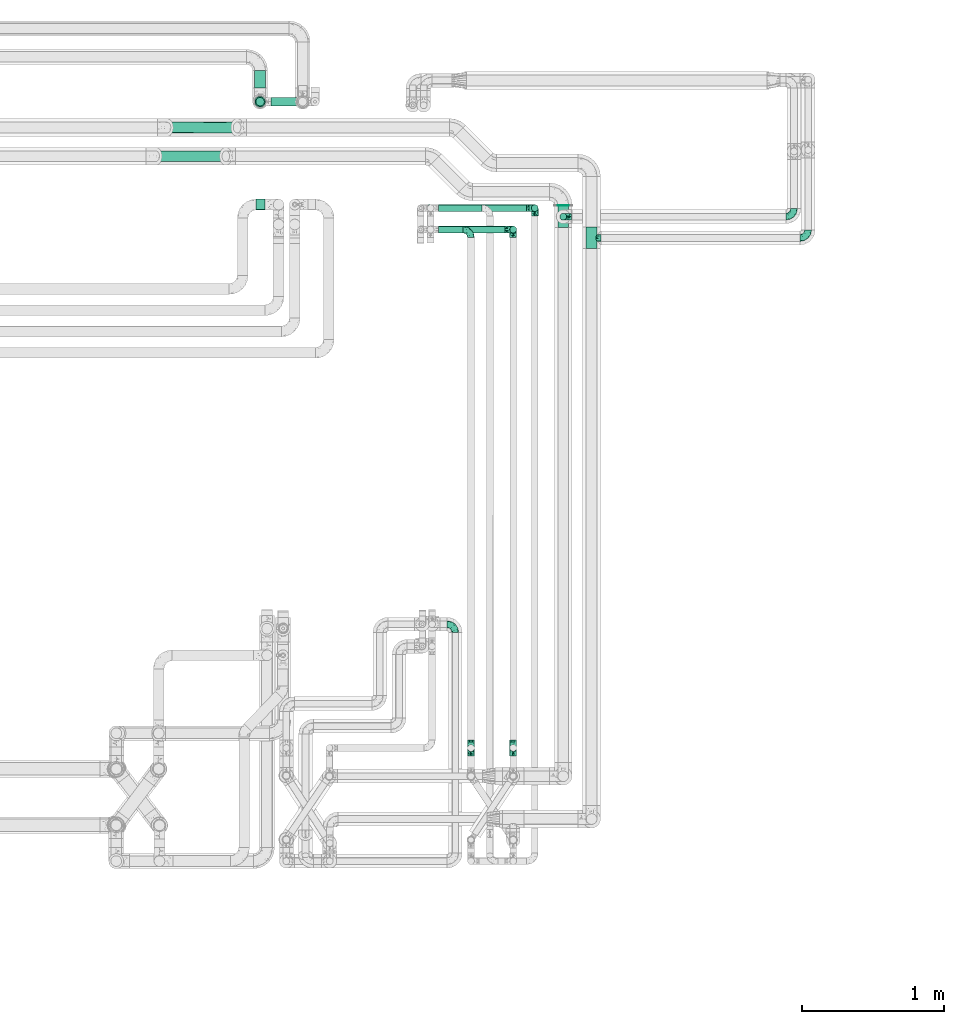
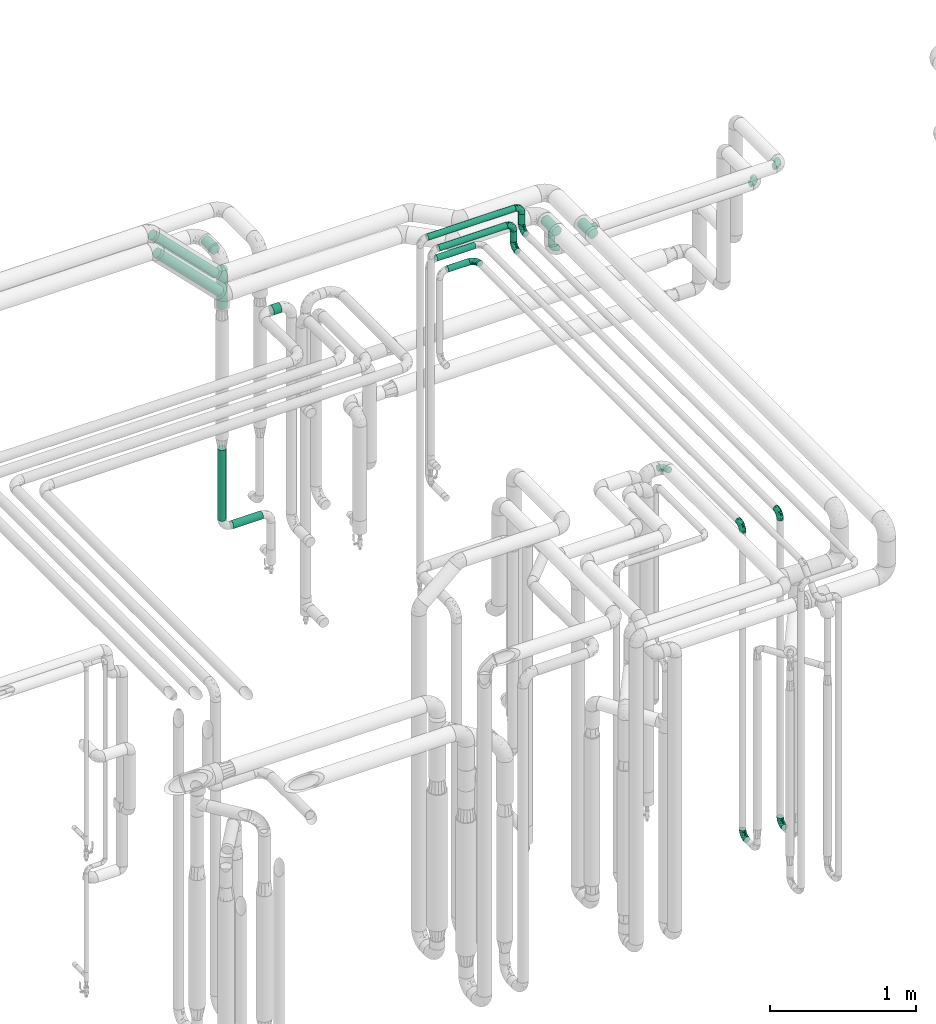
# One storey, part 680 of 827: 15 flow fittings, 15 flow segments.
"""IFC2X3 building model written with IfcOpenShell, lengths in millimetres."""

from ifc_helpers import new_model, entity, si_unit, converted_unit, derived_unit, direction, frame, origin, origin_2d_with_axis, place, context, subcontext, project, spatial, circle, extrude, faceted_brep, source, transform, mapped, material, type_object, type_shapes, element, save


model = new_model("IFC2X3")

# Units and contexts
model_context = context("Model", 3, precision=0.01, world=origin(), true_north=direction((6.12303176911189e-17, 1.0)))
body_context = subcontext(model_context, "Body", "Model", "MODEL_VIEW")
ifc_project = project(units=[si_unit("LENGTHUNIT", "METRE", prefix="MILLI"), si_unit("AREAUNIT", "SQUARE_METRE"), si_unit("VOLUMEUNIT", "CUBIC_METRE"), converted_unit("PLANEANGLEUNIT", "DEGREE", entity("IfcRatioMeasure", 0.0174532925199433), si_unit("PLANEANGLEUNIT", "RADIAN"), dimensions=[0, 0, 0, 0, 0, 0, 0]), si_unit("MASSUNIT", "GRAM", prefix="KILO"), derived_unit("MASSDENSITYUNIT", [(si_unit("MASSUNIT", "GRAM", prefix="KILO"), 1), (si_unit("LENGTHUNIT", "METRE"), -3)]), derived_unit("MOMENTOFINERTIAUNIT", [(si_unit("LENGTHUNIT", "METRE"), 4)]), si_unit("TIMEUNIT", "SECOND"), si_unit("FREQUENCYUNIT", "HERTZ"), si_unit("THERMODYNAMICTEMPERATUREUNIT", "DEGREE_CELSIUS"), derived_unit("THERMALTRANSMITTANCEUNIT", [(si_unit("MASSUNIT", "GRAM", prefix="KILO"), 1), (si_unit("THERMODYNAMICTEMPERATUREUNIT", "KELVIN"), -1), (si_unit("TIMEUNIT", "SECOND"), -3)]), derived_unit("VOLUMETRICFLOWRATEUNIT", [(si_unit("LENGTHUNIT", "METRE"), 3), (si_unit("TIMEUNIT", "SECOND"), -1)]), derived_unit("MASSFLOWRATEUNIT", [(si_unit("MASSUNIT", "GRAM", prefix="KILO"), 1), (si_unit("TIMEUNIT", "SECOND"), -1)]), derived_unit("ROTATIONALFREQUENCYUNIT", [(si_unit("TIMEUNIT", "SECOND"), -1)]), si_unit("ELECTRICCURRENTUNIT", "AMPERE"), si_unit("ELECTRICVOLTAGEUNIT", "VOLT"), si_unit("POWERUNIT", "WATT"), si_unit("FORCEUNIT", "NEWTON", prefix="KILO"), si_unit("ILLUMINANCEUNIT", "LUX"), si_unit("LUMINOUSFLUXUNIT", "LUMEN"), si_unit("LUMINOUSINTENSITYUNIT", "CANDELA"), derived_unit("USERDEFINED", [(si_unit("MASSUNIT", "GRAM", prefix="KILO"), -1), (si_unit("LENGTHUNIT", "METRE"), -2), (si_unit("TIMEUNIT", "SECOND"), 3), (si_unit("LUMINOUSFLUXUNIT", "LUMEN"), 1)]), derived_unit("LINEARVELOCITYUNIT", [(si_unit("LENGTHUNIT", "METRE"), 1), (si_unit("TIMEUNIT", "SECOND"), -1)]), si_unit("PRESSUREUNIT", "PASCAL"), derived_unit("USERDEFINED", [(si_unit("LENGTHUNIT", "METRE"), -2), (si_unit("MASSUNIT", "GRAM", prefix="KILO"), 1), (si_unit("TIMEUNIT", "SECOND"), -2)]), derived_unit("LINEARFORCEUNIT", [(si_unit("MASSUNIT", "GRAM", prefix="KILO"), 1), (si_unit("LENGTHUNIT", "METRE"), 1), (si_unit("TIMEUNIT", "SECOND"), -2), (si_unit("LENGTHUNIT", "METRE"), -1)]), derived_unit("PLANARFORCEUNIT", [(si_unit("MASSUNIT", "GRAM", prefix="KILO"), 1), (si_unit("LENGTHUNIT", "METRE"), 1), (si_unit("TIMEUNIT", "SECOND"), -2), (si_unit("LENGTHUNIT", "METRE"), -2)])], contexts=[model_context])

# Site, building, storey
site_placement = place(None, origin())
site = spatial("IfcSite", under=ifc_project, at=site_placement, CompositionType="ELEMENT")
building_placement = place(site_placement, origin())
building = spatial("IfcBuilding", under=site, at=building_placement, CompositionType="ELEMENT")
storey_placement = place(building_placement, frame((0.0, 0.0, 28200.0)))
storey = spatial("IfcBuildingStorey", under=building, at=storey_placement, Name="08", CompositionType="ELEMENT", Elevation=28200.0)

# Flow segments
pipe_segment_type = type_object("IfcPipeSegmentType", PredefinedType="NOTDEFINED")
flow_segment_1_placement = place(storey_placement, frame((48619.25, 18154.93, 2857.0)))
element("IfcFlowSegment", 1, at=flow_segment_1_placement, inside=storey, type_object=pipe_segment_type, context=body_context, shape_type="SweptSolid", body=[
    extrude(circle(Radius=24.0, at=origin_2d_with_axis()), frame((25.6, 25.6, 0.0), z_axis=(0.0, 0.0, 1.0), x_axis=(-1.0, 0.0, 0.0)), (0.0, 0.0, 1.0), 75.9999999999611),
])
flow_segment_2_placement = place(storey_placement, frame((48605.5, 18256.53, 2960.65)))
element("IfcFlowSegment", 2, at=flow_segment_2_placement, inside=storey, type_object=pipe_segment_type, context=body_context, shape_type="SweptSolid", body=[
    extrude(circle(Radius=37.75, at=origin_2d_with_axis()), frame((39.35, 0.0, 39.35), z_axis=(0.0, 1.0, 0.0), x_axis=(-1.0, 0.0, 0.0)), (0.0, 0.0, 1.0), 4.1498271651662),
])
flow_segment_3_placement = place(storey_placement, frame((45743.36, 18567.35, 2999.54)))
element("IfcFlowSegment", 3, at=flow_segment_3_placement, inside=storey, type_object=pipe_segment_type, context=body_context, shape_type="SweptSolid", body=[
    extrude(circle(Radius=37.75, at=origin_2d_with_axis()), frame((28.29, 39.35, 522.64), z_axis=(0.70710678118652, 0.0, -0.707106781186575), x_axis=(0.0, 1.0, 0.0)), (0.0, 0.0, 1.0), 699.116571318315),
])
flow_segment_4_placement = place(storey_placement, frame((45823.35, 18769.58, 2999.54)))
element("IfcFlowSegment", 4, at=flow_segment_4_placement, inside=storey, type_object=pipe_segment_type, context=body_context, shape_type="SweptSolid", body=[
    extrude(circle(Radius=37.75, at=origin_2d_with_axis()), frame((28.29, 39.35, 522.64), z_axis=(0.707106197699199, 0.00128465974007588, -0.70710619769928), x_axis=(-0.00181678172828728, 0.999998349650714, 0.0)), (0.0, 0.0, 1.0), 699.117459348992),
])
flow_segment_5_placement = place(storey_placement, frame((48419.25, 18215.29, 3057.0)))
element("IfcFlowSegment", 5, at=flow_segment_5_placement, inside=storey, type_object=pipe_segment_type, context=body_context, shape_type="SweptSolid", body=[
    extrude(circle(Radius=24.0, at=origin_2d_with_axis()), frame((25.6, 25.6, 0.0), z_axis=(0.0, 0.0, 1.0), x_axis=(-1.0, 0.0, 0.0)), (0.0, 0.0, 1.0), 86.0000000000194),
])
flow_segment_6_placement = place(storey_placement, frame((47696.84, 18215.29, 3174.4)))
element("IfcFlowSegment", 6, at=flow_segment_6_placement, inside=storey, type_object=pipe_segment_type, context=body_context, shape_type="SweptSolid", body=[
    extrude(circle(Radius=24.0, at=origin_2d_with_axis()), frame((0.0, 25.6, 25.6), z_axis=(1.0, 0.0, 0.0), x_axis=(0.0, 1.0, 0.0)), (0.0, 0.0, 1.0), 691.000000000008),
])
flow_segment_7_placement = place(storey_placement, frame((48266.43, 18064.04, 3057.0)))
element("IfcFlowSegment", 7, at=flow_segment_7_placement, inside=storey, type_object=pipe_segment_type, context=body_context, shape_type="SweptSolid", body=[
    extrude(circle(Radius=24.0, at=origin_2d_with_axis()), frame((25.6, 25.6, 0.0), z_axis=(0.0, 0.0, 1.0), x_axis=(-1.0, 0.0, 0.0)), (0.0, 0.0, 1.0), 85.9999999999848),
])
flow_segment_8_placement = place(storey_placement, frame((47696.84, 18064.04, 3174.4)))
element("IfcFlowSegment", 8, at=flow_segment_8_placement, inside=storey, type_object=pipe_segment_type, context=body_context, shape_type="SweptSolid", body=[
    extrude(circle(Radius=24.0, at=origin_2d_with_axis()), frame((0.0, 25.6, 25.6), z_axis=(1.0, 0.0, 0.0), x_axis=(0.0, 1.0, 0.0)), (0.0, 0.0, 1.0), 538.181019584543),
])
flow_segment_9_placement = place(storey_placement, frame((47766.84, 18215.29, 2974.4)))
element("IfcFlowSegment", 9, at=flow_segment_9_placement, inside=storey, type_object=pipe_segment_type, context=body_context, shape_type="SweptSolid", body=[
    extrude(circle(Radius=24.0, at=origin_2d_with_axis()), frame((0.0, 25.6, 25.6), z_axis=(1.0, 0.0, 0.0), x_axis=(0.0, 1.0, 0.0)), (0.0, 0.0, 1.0), 304.983131111843),
])
flow_segment_10_placement = place(storey_placement, frame((47766.84, 18064.04, 2974.4)))
element("IfcFlowSegment", 10, at=flow_segment_10_placement, inside=storey, type_object=pipe_segment_type, context=body_context, shape_type="SweptSolid", body=[
    extrude(circle(Radius=24.0, at=origin_2d_with_axis()), frame((0.0, 25.6, 25.6), z_axis=(1.0, 0.0, 0.0), x_axis=(0.0, 1.0, 0.0)), (0.0, 0.0, 1.0), 170.999916890567),
])
flow_segment_11_placement = place(storey_placement, frame((46480.03, 18226.89, 2960.65)))
element("IfcFlowSegment", 11, at=flow_segment_11_placement, inside=storey, type_object=pipe_segment_type, context=body_context, shape_type="SweptSolid", body=[
    extrude(circle(Radius=37.75, at=origin_2d_with_axis()), frame((0.0, 39.35, 39.35), z_axis=(1.0, 0.0, 0.0), x_axis=(0.0, 1.0, 0.0)), (0.0, 0.0, 1.0), 62.9999997025611),
])
flow_segment_12_placement = place(storey_placement, frame((46476.22, 18959.63, 806.0)))
element("IfcFlowSegment", 12, at=flow_segment_12_placement, inside=storey, type_object=pipe_segment_type, context=body_context, shape_type="SweptSolid", body=[
    extrude(circle(Radius=30.0, at=origin_2d_with_axis()), frame((31.6, 31.6, 0.0), z_axis=(0.0, 0.0, 1.0), x_axis=(-1.0, 0.0, 0.0)), (0.0, 0.0, 1.0), 592.875000000036),
])
flow_segment_13_placement = place(storey_placement, frame((46583.82, 18959.63, 698.4)))
element("IfcFlowSegment", 13, at=flow_segment_13_placement, inside=storey, type_object=pipe_segment_type, context=body_context, shape_type="SweptSolid", body=[
    extrude(circle(Radius=30.0, at=origin_2d_with_axis()), frame((0.0, 31.6, 31.6), z_axis=(1.0, 0.0, 0.0), x_axis=(0.0, -1.0, 0.0)), (0.0, 0.0, 1.0), 235.500000000016),
])
flow_segment_14_placement = place(storey_placement, frame((46468.47, 19086.22, 2960.65)))
element("IfcFlowSegment", 14, at=flow_segment_14_placement, inside=storey, type_object=pipe_segment_type, context=body_context, shape_type="SweptSolid", body=[
    extrude(circle(Radius=37.75, at=origin_2d_with_axis()), frame((39.35, 0.0, 39.35), z_axis=(0.0, 1.0, 0.0), x_axis=(-1.0, 0.0, 0.0)), (0.0, 0.0, 1.0), 126.011600000002),
])
flow_segment_15_placement = place(storey_placement, frame((46468.47, 18951.88, 2580.0)))
element("IfcFlowSegment", 15, at=flow_segment_15_placement, inside=storey, type_object=pipe_segment_type, context=body_context, shape_type="SweptSolid", body=[
    extrude(circle(Radius=37.75, at=origin_2d_with_axis()), frame((39.35, 39.35, 0.0)), (0.0, 0.0, 1.0), 325.000000000008),
])

# Flow fittings
ifc_material = material()
pipe_fitting_type_1 = type_object("IfcPipeFittingType", Name="ADSK_1", PredefinedType="NOTDEFINED", material=ifc_material)
shared_shape_1 = source(origin(), body_context, "Body", "Brep", [
    faceted_brep([(-76.0, 9.85, -36.75), (-76.0, 0.0, -38.05), (-76.0, -9.85, -36.75), (-76.0, -19.03, -32.95), (-76.0, -26.91, -26.91), (-76.0, -32.95, -19.03), (-76.0, -36.75, -9.85), (-76.0, -38.05, 0.0), (-76.0, -36.75, 9.85), (-76.0, -32.95, 19.02), (-76.0, -26.91, 26.91), (-76.0, -19.03, 32.95), (-76.0, -9.85, 36.75), (-76.0, 0.0, 38.05), (-76.0, 9.85, 36.75), (-76.0, 19.02, 32.95), (-76.0, 26.91, 26.91), (-76.0, 32.95, 19.02), (-76.0, 36.75, 9.85), (-76.0, 38.05, 0.0), (-76.0, 36.75, -9.85), (-76.0, 32.95, -19.03), (-76.0, 26.91, -26.91), (-76.0, 19.02, -32.95), (76.0, 26.91, -26.91), (76.0, 32.95, -19.03), (76.0, 36.75, -9.85), (76.0, 38.05, 0.0), (76.0, 36.75, 9.85), (76.0, 32.95, 19.02), (76.0, 26.91, 26.91), (76.0, 19.02, 32.95), (76.0, 9.85, 36.75), (76.0, 0.0, 38.05), (76.0, -9.85, 36.75), (76.0, -19.03, 32.95), (76.0, -26.91, 26.91), (76.0, -32.95, 19.02), (76.0, -36.75, 9.85), (76.0, -38.05, 0.0), (76.0, -36.75, -9.85), (76.0, -32.95, -19.03), (76.0, -26.91, -26.91), (76.0, -19.03, -32.95), (76.0, -9.85, -36.75), (76.0, 0.0, -38.05), (76.0, 9.85, -36.75), (76.0, 19.02, -32.95), (22.62, -37.1, 8.45), (23.39, -37.58, 4.22), (24.15, -38.05, 0.0), (18.42, -34.7, 15.61), (4.31, -29.72, 23.76), (12.18, -31.83, 20.86), (8.24, -30.77, 22.31), (-24.15, -38.05, 0.0), (-23.39, -37.58, 4.22), (-22.63, -37.1, 8.44), (-18.43, -34.7, 15.61), (-12.18, -31.83, 20.85), (-4.31, -29.72, 23.76), (0.0, -29.72, 23.76), (4.31, -29.72, -23.76), (12.18, -31.83, -20.86), (8.24, -30.77, -22.31), (18.42, -34.7, -15.61), (22.62, -37.1, -8.45), (23.39, -37.58, -4.22), (-4.31, -29.72, -23.76), (-12.18, -31.83, -20.85), (-18.43, -34.7, -15.61), (0.0, -29.72, -23.76), (-22.63, -37.1, -8.44), (-23.39, -37.58, -4.22), (0.0, -67.0, -24.15), (6.25, -67.0, -23.33), (12.08, -67.0, -20.91), (17.08, -67.0, -17.08), (20.91, -67.0, -12.08), (23.33, -67.0, -6.25), (24.15, -67.0, 0.0), (23.33, -67.0, 6.25), (20.91, -67.0, 12.07), (17.08, -67.0, 17.08), (12.08, -67.0, 20.91), (6.25, -67.0, 23.33), (0.0, -67.0, 24.15), (-6.25, -67.0, 23.33), (-12.07, -67.0, 20.91), (-17.08, -67.0, 17.08), (-20.91, -67.0, 12.07), (-23.33, -67.0, 6.25), (-24.15, -67.0, 0.0), (-23.33, -67.0, -6.25), (-20.91, -67.0, -12.08), (-17.08, -67.0, -17.08), (-12.07, -67.0, -20.91), (-6.25, -67.0, -23.33)], [[[0, 1, 2, 3, 4, 5, 6, 7, 8, 9, 10, 11, 12, 13, 14, 15, 16, 17, 18, 19, 20, 21, 22, 23]], [[24, 25, 26, 27, 28, 29, 30, 31, 32, 33, 34, 35, 36, 37, 38, 39, 40, 41, 42, 43, 44, 45, 46, 47]], [[39, 38, 48]], [[39, 48, 49, 50]], [[38, 51, 48]], [[37, 36, 52]], [[53, 51, 37]], [[37, 52, 54, 53]], [[36, 10, 52]], [[37, 51, 38]], [[7, 55, 56, 57]], [[8, 7, 57]], [[57, 58, 8]], [[59, 60, 9]], [[59, 9, 58]], [[9, 60, 10]], [[58, 9, 8]], [[10, 60, 61, 52]], [[36, 35, 11, 10]], [[13, 12, 34, 33]], [[12, 11, 35, 34]], [[14, 13, 33, 32]], [[29, 28, 18, 17]], [[16, 15, 31, 30]], [[17, 16, 30, 29]], [[32, 31, 15, 14]], [[19, 18, 28, 27]], [[26, 25, 21, 20]], [[25, 24, 22, 21]], [[27, 26, 20, 19]], [[45, 44, 2, 1]], [[0, 23, 47, 46]], [[1, 0, 46, 45]], [[24, 47, 23, 22]], [[3, 2, 44, 43]], [[43, 42, 4, 3]], [[42, 41, 62]], [[41, 63, 64, 62]], [[41, 65, 63]], [[42, 62, 4]], [[40, 39, 66]], [[66, 65, 40]], [[39, 50, 67, 66]], [[40, 65, 41]], [[68, 69, 5]], [[5, 4, 68]], [[69, 70, 5]], [[4, 62, 71, 68]], [[70, 72, 6]], [[72, 7, 6]], [[7, 72, 73, 55]], [[70, 6, 5]], [[74, 75, 76, 77, 78, 79, 80, 81, 82, 83, 84, 85, 86, 87, 88, 89, 90, 91, 92, 93, 94, 95, 96, 97]], [[56, 92, 91]], [[86, 60, 87]], [[59, 89, 88]], [[84, 54, 85]], [[49, 80, 50]], [[59, 88, 87]], [[49, 48, 81]], [[91, 57, 56]], [[55, 92, 56]], [[57, 91, 90]], [[57, 90, 58]], [[89, 58, 90]], [[89, 59, 58]], [[87, 60, 59]], [[86, 52, 61, 60]], [[84, 53, 54]], [[83, 53, 84]], [[48, 82, 81]], [[83, 82, 51]], [[52, 86, 85]], [[54, 52, 85]], [[53, 83, 51]], [[51, 82, 48]], [[80, 49, 81]], [[79, 67, 80]], [[77, 65, 78]], [[64, 76, 75]], [[79, 66, 67]], [[78, 66, 79]], [[63, 77, 76]], [[67, 50, 80]], [[66, 78, 65]], [[75, 62, 64]], [[63, 65, 77]], [[74, 68, 71, 62]], [[74, 62, 75]], [[73, 92, 55]], [[69, 97, 96]], [[73, 72, 93]], [[95, 69, 96]], [[72, 94, 93]], [[95, 94, 70]], [[68, 74, 97]], [[97, 69, 68]], [[69, 95, 70]], [[70, 94, 72]], [[92, 73, 93]], [[64, 63, 76]]]),
])
type_shapes(pipe_fitting_type_1, [shared_shape_1])
for number, where, z_axis, x_axis, name in (
    (16, (48845.03, 18030.53, 3000.0), (0.0, 0.0, 1.0), (0.0, 1.0, 0.0), "ADSK_1"),
    (17, (48644.84, 18180.53, 3000.0), (1.0, 0.0, 0.0), (0.0, 1.0, 0.0), "ADSK_1"),
):
    element("IfcFlowFitting", number, at=place(storey_placement, frame(where, z_axis=z_axis, x_axis=x_axis)), inside=storey, type_object=pipe_fitting_type_1, material=ifc_material, Name=name, ObjectType="ADSK_1", context=body_context, shape_type="MappedRepresentation", body=[
        mapped(shared_shape_1, transform((0.0, 0.0, 0.0), scale=1.0)),
    ])
pipe_fitting_type_2 = type_object("IfcPipeFittingType", Name="ADSK_1", PredefinedType="NOTDEFINED", material=ifc_material)
shared_shape_2 = source(origin(), body_context, "Body", "Brep", [
    faceted_brep([(-57.0, 12.07, -20.91), (-57.0, 6.25, -23.33), (-57.0, 0.0, -24.15), (-57.0, -6.25, -23.33), (-57.0, -12.08, -20.91), (-57.0, -17.08, -17.08), (-57.0, -20.91, -12.08), (-57.0, -23.33, -6.25), (-57.0, -24.15, 0.0), (-57.0, -23.33, 6.25), (-57.0, -20.91, 12.07), (-57.0, -17.08, 17.08), (-57.0, -12.08, 20.91), (-57.0, -6.25, 23.33), (-57.0, 0.0, 24.15), (-57.0, 6.25, 23.33), (-57.0, 12.07, 20.91), (-57.0, 17.08, 17.08), (-57.0, 20.91, 12.07), (-57.0, 23.33, 6.25), (-57.0, 24.15, 0.0), (-57.0, 23.33, -6.25), (-57.0, 20.91, -12.08), (-57.0, 17.08, -17.08), (0.0, 57.0, -24.15), (-6.25, 57.0, -23.33), (-12.07, 57.0, -20.91), (-17.08, 57.0, -17.08), (-20.91, 57.0, -12.08), (-23.33, 57.0, -6.25), (-24.15, 57.0, 0.0), (-23.33, 57.0, 6.25), (-20.91, 57.0, 12.07), (-17.08, 57.0, 17.08), (-12.07, 57.0, 20.91), (-6.25, 57.0, 23.33), (0.0, 57.0, 24.15), (6.25, 57.0, 23.33), (12.08, 57.0, 20.91), (17.08, 57.0, 17.08), (20.91, 57.0, 12.07), (23.33, 57.0, 6.25), (24.15, 57.0, 0.0), (23.33, 57.0, -6.25), (20.91, 57.0, -12.08), (17.08, 57.0, -17.08), (12.08, 57.0, -20.91), (6.25, 57.0, -23.33), (14.9, 21.14, 6.17), (13.61, 24.64, 12.48), (6.23, 8.95, 8.98), (-41.47, -21.06, 0.0), (-41.92, -18.38, 13.72), (-24.64, -13.61, 12.48), (-37.37, -13.24, 18.15), (-6.8, -4.93, 8.18), (-21.76, -15.19, 6.22), (-12.78, -9.18, 0.0), (-37.73, -20.51, 7.75), (-7.38, 7.38, 20.24), (-23.37, -4.26, 20.42), (-11.9, -3.19, 15.86), (-42.14, -8.7, 21.82), (13.24, 37.37, 18.15), (9.33, 23.53, 16.85), (4.26, 23.37, 20.42), (2.77, 10.92, 15.55), (-29.46, 0.91, 23.52), (-44.13, 20.56, 15.69), (-39.25, 26.33, 10.88), (-49.02, 22.92, 9.96), (-34.58, 23.87, 17.15), (-15.8, 6.8, 22.81), (-8.67, 20.47, 23.88), (-18.12, 12.9, 24.08), (-48.29, 14.92, 19.65), (-44.06, -2.85, 23.78), (-9.23, 48.95, 22.58), (-3.78, 42.74, 24.07), (-40.34, 4.26, 24.09), (-44.02, 26.14, 5.46), (-44.04, 9.88, 22.74), (-4.95, 16.87, 22.52), (-2.75, 1.43, 12.5), (-25.48, 40.98, 10.71), (20.51, 37.73, 7.75), (18.38, 41.92, 13.72), (8.7, 42.14, 21.82), (-25.95, -17.97, 0.0), (2.85, 44.06, 23.78), (21.06, 41.47, 0.0), (17.97, 25.95, 0.0), (-24.04, -9.27, 17.13), (-33.26, 33.26, 5.86), (-28.55, 40.57, 0.0), (-40.57, 28.55, 0.0), (-25.29, 47.19, 4.06), (-27.01, 31.1, 16.77), (-15.7, 43.95, 19.9), (-20.27, 45.22, 15.61), (-30.53, 31.98, 12.64), (-11.28, 38.33, 22.92), (-9.97, 27.88, 24.09), (-20.15, 30.26, 21.25), (-31.25, 11.75, 23.64), (-28.75, 7.23, 24.15), (-29.53, 18.06, 22.27), (-28.44, 24.21, 20.02), (-37.55, 17.7, 20.26), (-15.88, 29.25, 22.99), (-20.82, 20.82, 23.44), (-0.91, 29.46, 23.52), (-13.5, -7.67, 12.04), (1.49, 1.56, 5.16), (8.86, 10.35, 4.59), (0.38, -0.38, 0.0), (9.18, 12.78, 0.0), (-37.37, -13.24, -18.15), (8.86, 10.35, -4.59), (-45.22, 20.27, -15.61), (-43.95, 15.7, -19.9), (-38.33, 11.28, -22.92), (-48.95, 9.23, -22.58), (-47.19, 25.29, -4.06), (-33.26, 33.26, -5.86), (18.38, 41.92, -13.72), (-30.26, 20.15, -21.25), (2.85, 44.06, -23.78), (-4.26, 40.34, -24.09), (-40.98, 25.48, -10.71), (-41.92, -18.38, -13.72), (9.25, 23.5, -16.92), (4.26, 23.37, -20.42), (13.24, 37.37, -18.15), (-37.73, -20.51, -7.75), (-11.75, 31.25, -23.64), (-7.23, 28.75, -24.15), (-12.9, 18.12, -24.08), (8.7, 42.14, -21.82), (-44.06, -2.85, -23.78), (-6.8, 15.8, -22.81), (-20.47, 8.67, -23.88), (-24.64, -13.61, -12.48), (-42.74, 3.78, -24.07), (-18.06, 29.53, -22.27), (-24.21, 28.44, -20.02), (-27.88, 9.97, -24.09), (-31.1, 27.01, -16.77), (-26.14, 44.02, -5.46), (14.9, 21.14, -6.17), (20.51, 37.73, -7.75), (-9.88, 44.04, -22.74), (-20.56, 44.13, -15.69), (-21.76, -15.19, -6.22), (-13.5, -7.67, -12.04), (-24.14, -9.76, -16.74), (-11.9, -3.19, -15.86), (-14.92, 48.29, -19.65), (-23.37, -4.26, -20.42), (-0.91, 29.46, -23.52), (-26.33, 39.25, -10.88), (-23.87, 34.58, -17.15), (-42.14, -8.7, -21.82), (-22.92, 49.02, -9.96), (13.61, 24.64, -12.48), (-31.98, 30.53, -12.64), (-16.87, 4.95, -22.52), (-17.7, 37.55, -20.26), (-29.25, 15.88, -22.99), (-20.82, 20.82, -23.44), (-29.46, 0.91, -23.52), (-7.38, 7.38, -20.24), (2.77, 10.92, -15.55), (6.23, 8.95, -8.98), (-6.8, -4.93, -8.18), (-2.81, 1.41, -12.54), (1.49, 1.56, -5.16)], [[[0, 1, 2, 3, 4, 5, 6, 7, 8, 9, 10, 11, 12, 13, 14, 15, 16, 17, 18, 19, 20, 21, 22, 23]], [[24, 25, 26, 27, 28, 29, 30, 31, 32, 33, 34, 35, 36, 37, 38, 39, 40, 41, 42, 43, 44, 45, 46, 47]], [[48, 49, 50]], [[9, 8, 51]], [[52, 53, 54]], [[55, 56, 57]], [[10, 58, 52]], [[9, 58, 10]], [[59, 60, 61]], [[54, 12, 11]], [[54, 62, 12]], [[63, 39, 38]], [[64, 65, 66]], [[62, 60, 67]], [[68, 69, 70]], [[71, 69, 68]], [[72, 73, 74]], [[16, 75, 17]], [[13, 76, 14]], [[35, 77, 78]], [[14, 79, 15]], [[17, 68, 18]], [[14, 76, 79]], [[20, 19, 80]], [[70, 19, 18]], [[81, 15, 79]], [[15, 81, 16]], [[73, 72, 82]], [[66, 83, 50]], [[32, 31, 84]], [[85, 86, 49]], [[63, 87, 65]], [[56, 58, 88]], [[36, 89, 37]], [[85, 41, 40]], [[36, 35, 78]], [[90, 41, 85]], [[40, 39, 86]], [[12, 62, 13]], [[86, 85, 40]], [[48, 85, 49]], [[85, 91, 90]], [[87, 38, 37]], [[92, 60, 54]], [[80, 69, 93]], [[93, 94, 95]], [[10, 52, 11]], [[94, 96, 30]], [[97, 98, 99]], [[80, 93, 95]], [[100, 97, 84]], [[99, 98, 33]], [[101, 102, 78]], [[103, 101, 98]], [[96, 31, 30]], [[77, 98, 101]], [[77, 35, 34]], [[34, 33, 98]], [[9, 51, 58]], [[87, 63, 38]], [[104, 105, 74]], [[106, 103, 107]], [[106, 81, 104]], [[75, 68, 17]], [[108, 107, 71]], [[33, 32, 99]], [[109, 103, 110]], [[101, 109, 102]], [[89, 78, 111]], [[53, 52, 58]], [[54, 11, 52]], [[60, 62, 54]], [[88, 58, 51]], [[76, 62, 67]], [[53, 112, 92]], [[60, 59, 72]], [[39, 63, 86]], [[49, 86, 63]], [[89, 87, 37]], [[42, 41, 90]], [[111, 82, 65]], [[111, 65, 87]], [[65, 59, 66]], [[104, 81, 79]], [[75, 81, 108]], [[32, 84, 99]], [[97, 99, 84]], [[98, 97, 103]], [[106, 107, 108]], [[74, 102, 110]], [[111, 78, 102]], [[74, 110, 104]], [[74, 67, 72]], [[61, 92, 112]], [[66, 59, 61]], [[56, 53, 58]], [[66, 50, 49]], [[61, 112, 83]], [[66, 49, 64]], [[78, 89, 36]], [[87, 89, 111]], [[62, 76, 13]], [[79, 76, 67]], [[100, 93, 69]], [[96, 93, 84]], [[55, 113, 50]], [[113, 114, 50]], [[104, 79, 105]], [[106, 104, 110]], [[20, 80, 95]], [[85, 48, 91]], [[115, 114, 113]], [[116, 91, 48]], [[70, 80, 19]], [[93, 96, 94]], [[84, 31, 96]], [[103, 106, 110]], [[81, 106, 108]], [[103, 97, 107]], [[71, 107, 97]], [[71, 97, 100]], [[108, 71, 68]], [[79, 67, 105]], [[67, 74, 105]], [[115, 113, 57]], [[112, 56, 55]], [[56, 88, 57]], [[60, 72, 67]], [[82, 72, 59]], [[65, 82, 59]], [[82, 111, 73]], [[111, 102, 73]], [[102, 74, 73]], [[81, 75, 16]], [[68, 75, 108]], [[68, 70, 18]], [[80, 70, 69]], [[98, 77, 34]], [[78, 77, 101]], [[93, 100, 84]], [[71, 100, 69]], [[102, 109, 110]], [[101, 103, 109]], [[53, 92, 54]], [[61, 60, 92]], [[56, 112, 53]], [[83, 112, 55]], [[50, 83, 55]], [[61, 83, 66]], [[49, 63, 64]], [[65, 64, 63]], [[57, 113, 55]], [[114, 115, 116]], [[116, 48, 114]], [[48, 50, 114]], [[117, 5, 4]], [[116, 115, 118]], [[119, 120, 23]], [[121, 122, 120]], [[95, 123, 20]], [[0, 23, 120]], [[124, 95, 94]], [[125, 45, 44]], [[121, 120, 126]], [[24, 127, 128]], [[22, 21, 129]], [[0, 122, 1]], [[5, 117, 130]], [[131, 132, 133]], [[134, 88, 51]], [[135, 136, 137]], [[6, 5, 130]], [[46, 138, 47]], [[139, 3, 2]], [[140, 141, 137]], [[6, 134, 7]], [[134, 130, 142]], [[143, 2, 1]], [[144, 126, 145]], [[121, 146, 143]], [[147, 120, 119]], [[94, 148, 124]], [[149, 150, 91]], [[30, 29, 148]], [[151, 25, 128]], [[27, 152, 28]], [[134, 153, 88]], [[154, 155, 156]], [[27, 26, 157]], [[151, 26, 25]], [[155, 158, 156]], [[24, 47, 127]], [[1, 122, 143]], [[138, 132, 159]], [[160, 152, 161]], [[24, 128, 25]], [[46, 133, 138]], [[162, 117, 4]], [[148, 160, 124]], [[152, 160, 163]], [[154, 142, 155]], [[45, 125, 133]], [[133, 46, 45]], [[125, 164, 133]], [[51, 7, 134]], [[42, 90, 43]], [[165, 147, 129]], [[153, 134, 142]], [[43, 150, 44]], [[162, 4, 3]], [[141, 140, 166]], [[117, 162, 158]], [[163, 29, 28]], [[43, 90, 150]], [[123, 21, 20]], [[144, 151, 135]], [[157, 152, 27]], [[167, 145, 161]], [[23, 22, 119]], [[168, 126, 169]], [[121, 168, 146]], [[139, 143, 170]], [[142, 130, 117]], [[8, 7, 51]], [[134, 6, 130]], [[139, 162, 3]], [[170, 166, 158]], [[170, 158, 162]], [[158, 171, 156]], [[44, 150, 125]], [[91, 150, 90]], [[164, 125, 150]], [[132, 138, 133]], [[127, 138, 159]], [[131, 164, 172]], [[132, 171, 140]], [[135, 151, 128]], [[157, 151, 167]], [[22, 129, 119]], [[147, 119, 129]], [[120, 147, 126]], [[144, 145, 167]], [[137, 146, 169]], [[170, 143, 146]], [[137, 169, 135]], [[137, 159, 140]], [[171, 172, 156]], [[173, 174, 175]], [[156, 175, 154]], [[174, 57, 153]], [[132, 172, 171]], [[172, 164, 173]], [[143, 139, 2]], [[162, 139, 170]], [[138, 127, 47]], [[128, 127, 159]], [[165, 124, 160]], [[123, 124, 129]], [[149, 173, 164]], [[176, 174, 173]], [[135, 128, 136]], [[144, 135, 169]], [[150, 149, 164]], [[176, 118, 115]], [[149, 91, 116]], [[30, 148, 94]], [[163, 148, 29]], [[124, 123, 95]], [[129, 21, 123]], [[126, 144, 169]], [[151, 144, 167]], [[126, 147, 145]], [[161, 145, 147]], [[161, 147, 165]], [[167, 161, 152]], [[128, 159, 136]], [[159, 137, 136]], [[154, 153, 142]], [[132, 140, 159]], [[174, 176, 57]], [[57, 88, 153]], [[166, 140, 171]], [[158, 166, 171]], [[166, 170, 141]], [[170, 146, 141]], [[146, 137, 141]], [[151, 157, 26]], [[152, 157, 167]], [[152, 163, 28]], [[148, 163, 160]], [[120, 122, 0]], [[143, 122, 121]], [[124, 165, 129]], [[161, 165, 160]], [[146, 168, 169]], [[121, 126, 168]], [[142, 117, 155]], [[158, 155, 117]], [[175, 156, 172]], [[153, 154, 174]], [[173, 175, 172]], [[174, 154, 175]], [[164, 131, 133]], [[172, 132, 131]], [[176, 173, 118]], [[57, 176, 115]], [[173, 149, 118]], [[149, 116, 118]]]),
])
type_shapes(pipe_fitting_type_2, [shared_shape_2])
for number, where, name in (
    (18, (50372.03, 18030.53, 3000.0), "ADSK_1"),
    (19, (50272.03, 18180.53, 2800.0), "ADSK_1"),
):
    element("IfcFlowFitting", number, at=place(storey_placement, frame(where)), inside=storey, type_object=pipe_fitting_type_2, material=ifc_material, Name=name, ObjectType="ADSK_1", context=body_context, shape_type="MappedRepresentation", body=[
        mapped(shared_shape_2, transform((0.0, 0.0, 0.0), scale=1.0)),
    ])
for number, where, z_axis, x_axis, name in (
    (20, (48644.84, 18180.53, 2800.0), (0.0, 1.0, 0.0), (-1.0, 0.0, 0.0), "ADSK_1"),
    (21, (48292.02, 14435.0, 3000.0), (1.0, 0.0, 0.0), (0.0, -1.0, 0.0), "ADSK_1"),
    (22, (48292.02, 14435.0, 400.0), (-1.0, 0.0, 0.0), (0.0, 0.0, -1.0), "ADSK_1"),
    (23, (47994.84, 14434.53, 3000.0), (1.0, 0.0, 0.0), (0.0, -1.0, 0.0), "ADSK_1"),
    (24, (47994.84, 14434.53, 400.0), (1.0, 0.0, 0.0), (0.0, 1.0, 0.0), "ADSK_1"),
    (25, (48444.84, 18240.89, 3000.0), (1.0, 0.0, 0.0), (0.0, 1.0, 0.0), "ADSK_1"),
    (26, (48444.84, 18240.89, 3200.0), (0.0, -1.0, 0.0), (0.0, 0.0, 1.0), "ADSK_1"),
    (27, (48292.02, 18089.64, 3000.0), (1.0, 0.0, 0.0), (0.0, 1.0, 0.0), "ADSK_1"),
    (28, (48292.02, 18089.64, 3200.0), (0.0, -1.0, 0.0), (0.0, 0.0, 1.0), "ADSK_1"),
    (29, (47994.84, 18089.64, 3000.0), (0.0, 0.0, 1.0), (0.0, 1.0, 0.0), "ADSK_1"),
    (30, (47884.01, 15307.03, 3000.0), (0.0, 0.0, 1.0), (0.0, 1.0, 0.0), "ADSK_1"),
):
    element("IfcFlowFitting", number, at=place(storey_placement, frame(where, z_axis=z_axis, x_axis=x_axis)), inside=storey, type_object=pipe_fitting_type_2, material=ifc_material, Name=name, ObjectType="ADSK_1", context=body_context, shape_type="MappedRepresentation", body=[
        mapped(shared_shape_2, transform((0.0, 0.0, 0.0), scale=1.0)),
    ])

save(model, "model.ifc")
